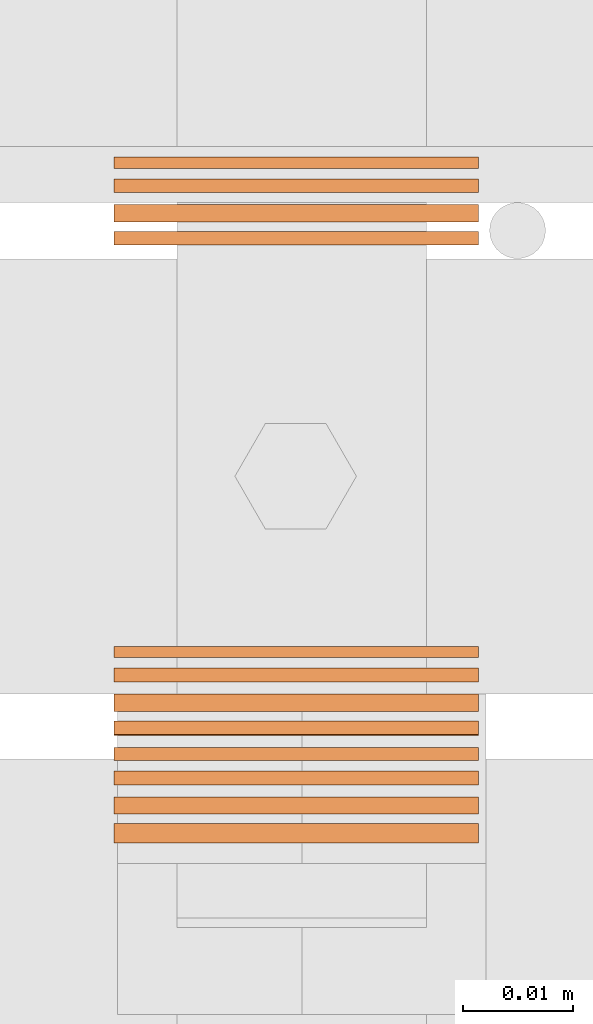
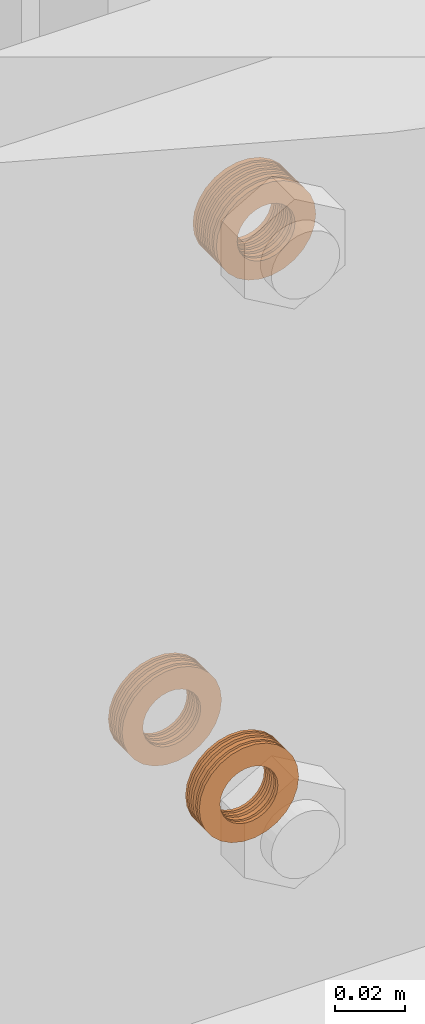
# One storey, part 34 of 44: 5 proxies.
"""IFC4 building model written with IfcOpenShell, lengths in feet."""

from ifc_helpers import new_model, entity, si_unit, converted_unit, derived_unit, direction, frame, frame_2d, origin, origin_2d_with_axis, place, context, subcontext, project, spatial, circle_curve, parameter, trimmed, segment, composite_curve, outline, extrude, source, transform, mapped, material, type_object, type_shapes, element, save


model = new_model("IFC4")

# Units and contexts
model_context = context("Model", 3, precision=0.0001, world=origin(), true_north=direction((6.12303176911189e-17, 1.0)))
body_context = subcontext(model_context, "Body", "Model", "MODEL_VIEW")
ifc_project = project(units=[converted_unit("LENGTHUNIT", "FOOT", entity("IfcRatioMeasure", 0.3048), si_unit("LENGTHUNIT", "METRE"), dimensions=[1, 0, 0, 0, 0, 0, 0]), converted_unit("AREAUNIT", "SQUARE FOOT", entity("IfcRatioMeasure", 0.09290304), si_unit("AREAUNIT", "SQUARE_METRE"), dimensions=[2, 0, 0, 0, 0, 0, 0]), converted_unit("VOLUMEUNIT", "CUBIC FOOT", entity("IfcRatioMeasure", 0.028316846592), si_unit("VOLUMEUNIT", "CUBIC_METRE"), dimensions=[3, 0, 0, 0, 0, 0, 0]), converted_unit("PLANEANGLEUNIT", "DEGREE", entity("IfcRatioMeasure", 0.0174532925199433), si_unit("PLANEANGLEUNIT", "RADIAN"), dimensions=[0, 0, 0, 0, 0, 0, 0]), si_unit("MASSUNIT", "GRAM", prefix="KILO"), derived_unit("MASSDENSITYUNIT", [(si_unit("MASSUNIT", "GRAM", prefix="KILO"), 1), (si_unit("LENGTHUNIT", "METRE"), -3)]), derived_unit("MOMENTOFINERTIAUNIT", [(si_unit("LENGTHUNIT", "METRE"), 4)]), si_unit("TIMEUNIT", "SECOND"), si_unit("FREQUENCYUNIT", "HERTZ"), si_unit("THERMODYNAMICTEMPERATUREUNIT", "DEGREE_CELSIUS"), derived_unit("THERMALTRANSMITTANCEUNIT", [(si_unit("MASSUNIT", "GRAM", prefix="KILO"), 1), (si_unit("THERMODYNAMICTEMPERATUREUNIT", "KELVIN"), -1), (si_unit("TIMEUNIT", "SECOND"), -3)]), derived_unit("VOLUMETRICFLOWRATEUNIT", [(si_unit("LENGTHUNIT", "METRE"), 3), (si_unit("TIMEUNIT", "SECOND"), -1)]), si_unit("ELECTRICCURRENTUNIT", "AMPERE"), si_unit("ELECTRICVOLTAGEUNIT", "VOLT"), si_unit("POWERUNIT", "WATT"), si_unit("FORCEUNIT", "NEWTON"), si_unit("ILLUMINANCEUNIT", "LUX"), si_unit("LUMINOUSFLUXUNIT", "LUMEN"), si_unit("LUMINOUSINTENSITYUNIT", "CANDELA"), derived_unit("USERDEFINED", [(si_unit("MASSUNIT", "GRAM", prefix="KILO"), -1), (si_unit("LENGTHUNIT", "METRE"), -2), (si_unit("TIMEUNIT", "SECOND"), 3), (si_unit("LUMINOUSFLUXUNIT", "LUMEN"), 1)]), derived_unit("LINEARVELOCITYUNIT", [(si_unit("LENGTHUNIT", "METRE"), 1), (si_unit("TIMEUNIT", "SECOND"), -1)]), si_unit("PRESSUREUNIT", "PASCAL"), derived_unit("USERDEFINED", [(si_unit("LENGTHUNIT", "METRE"), -2), (si_unit("MASSUNIT", "GRAM", prefix="KILO"), 1), (si_unit("TIMEUNIT", "SECOND"), -2)]), derived_unit("LINEARFORCEUNIT", [(si_unit("MASSUNIT", "GRAM", prefix="KILO"), 1), (si_unit("LENGTHUNIT", "METRE"), 1), (si_unit("TIMEUNIT", "SECOND"), -2), (si_unit("LENGTHUNIT", "METRE"), -1)]), derived_unit("PLANARFORCEUNIT", [(si_unit("MASSUNIT", "GRAM", prefix="KILO"), 1), (si_unit("LENGTHUNIT", "METRE"), 1), (si_unit("TIMEUNIT", "SECOND"), -2), (si_unit("LENGTHUNIT", "METRE"), -2)])], contexts=[model_context])

# Site, building, storey
site_placement = place(None, origin())
site = spatial("IfcSite", under=ifc_project, at=site_placement, CompositionType="ELEMENT")
building_placement = place(site_placement, origin())
building = spatial("IfcBuilding", under=site, at=building_placement, CompositionType="ELEMENT")
storey_placement = place(building_placement, origin())
storey = spatial("IfcBuildingStorey", under=building, at=storey_placement, CompositionType="ELEMENT", Elevation=0.0)

# Proxies
ifc_material = material(Name="(2) GALV. (FOR DRAINAGE)", Category="Materials")
building_element_proxy_type_1 = type_object("IfcBuildingElementProxyType", Name="WASHER240:WASHER", PredefinedType="NOTDEFINED", material=ifc_material)
shared_shape_1 = source(origin(), body_context, "Body", "SweptSolid", [
    extrude(outline(composite_curve([segment(trimmed(circle_curve(origin_2d_with_axis(), 0.054126587736544), [parameter(360.0)], [parameter(180.0)], True, "PARAMETER"), True, "CONTINUOUS"), segment(trimmed(circle_curve(origin_2d_with_axis(), 0.054126587736544), [parameter(180.0)], [parameter(360.0)], True, "PARAMETER"), True, "CONTINUOUS")], self_intersect=False), holes=[composite_curve([segment(trimmed(circle_curve(frame_2d((0.0, 0.00204962727015712), x_axis=(1.0, 0.0)), 0.031438579453031), [parameter(180.0)], [parameter(360.0)], True, "PARAMETER"), False, "CONTINUOUS"), segment(trimmed(circle_curve(frame_2d((0.0, 0.00204962727015712), x_axis=(1.0, 0.0)), 0.031438579453031), [parameter(360.0)], [parameter(180.0)], True, "PARAMETER"), False, "CONTINUOUS")], self_intersect=False)]), frame((0.0, 0.0593604205315437, 0.0593604205315437), z_axis=(1.0, 0.0, 0.0), x_axis=(0.0, -1.0, 0.0)), (0.0, 0.0, 1.0), 0.00519959634584666),
    extrude(outline(composite_curve([segment(trimmed(circle_curve(origin_2d_with_axis(), 0.054126587736544), [parameter(180.0)], [parameter(360.0)], True, "PARAMETER"), True, "CONTINUOUS"), segment(trimmed(circle_curve(origin_2d_with_axis(), 0.054126587736544), [parameter(360.0)], [parameter(180.0)], True, "PARAMETER"), True, "CONTINUOUS")], self_intersect=False), holes=[composite_curve([segment(trimmed(circle_curve(frame_2d((0.0, 0.00204962727015712), x_axis=(1.0, 0.0)), 0.031438579453031), [parameter(360.0)], [parameter(180.0)], True, "PARAMETER"), False, "CONTINUOUS"), segment(trimmed(circle_curve(frame_2d((0.0, 0.00204962727015712), x_axis=(1.0, 0.0)), 0.031438579453031), [parameter(180.0)], [parameter(360.0)], True, "PARAMETER"), False, "CONTINUOUS")], self_intersect=False)]), frame((0.0385633439132107, 0.0593604205315437, 0.0593604205315437), z_axis=(1.0, 0.0, 0.0), x_axis=(0.0, -1.0, 0.0)), (0.0, 0.0, 1.0), 0.00570828538684509),
    extrude(outline(composite_curve([segment(trimmed(circle_curve(origin_2d_with_axis(), 0.054126587736544), [parameter(180.0)], [parameter(360.0)], True, "PARAMETER"), True, "CONTINUOUS"), segment(trimmed(circle_curve(origin_2d_with_axis(), 0.054126587736544), [parameter(360.0)], [parameter(180.0)], True, "PARAMETER"), True, "CONTINUOUS")], self_intersect=False), holes=[composite_curve([segment(trimmed(circle_curve(frame_2d((0.0, 0.00204962727015712), x_axis=(1.0, 0.0)), 0.031438579453031), [parameter(360.0)], [parameter(180.0)], True, "PARAMETER"), False, "CONTINUOUS"), segment(trimmed(circle_curve(frame_2d((0.0, 0.00204962727015712), x_axis=(1.0, 0.0)), 0.031438579453031), [parameter(180.0)], [parameter(360.0)], True, "PARAMETER"), False, "CONTINUOUS")], self_intersect=False)]), frame((0.0306092216351317, 0.0593604205315437, 0.0593604205315437), z_axis=(1.0, 0.0, 0.0), x_axis=(0.0, -1.0, 0.0)), (0.0, 0.0, 1.0), 0.0051228935196832),
    extrude(outline(composite_curve([segment(trimmed(circle_curve(origin_2d_with_axis(), 0.054126587736544), [parameter(180.0)], [parameter(360.0)], True, "PARAMETER"), True, "CONTINUOUS"), segment(trimmed(circle_curve(origin_2d_with_axis(), 0.054126587736544), [parameter(360.0)], [parameter(180.0)], True, "PARAMETER"), True, "CONTINUOUS")], self_intersect=False), holes=[composite_curve([segment(trimmed(circle_curve(frame_2d((0.0, 0.00204962727015712), x_axis=(1.0, 0.0)), 0.031438579453031), [parameter(360.0)], [parameter(180.0)], True, "PARAMETER"), False, "CONTINUOUS"), segment(trimmed(circle_curve(frame_2d((0.0, 0.00204962727015712), x_axis=(1.0, 0.0)), 0.031438579453031), [parameter(180.0)], [parameter(360.0)], True, "PARAMETER"), False, "CONTINUOUS")], self_intersect=False)]), frame((0.0159873593368047, 0.0593604205315437, 0.0593604205315437), z_axis=(1.0, 0.0, 0.0), x_axis=(0.0, -1.0, 0.0)), (0.0, 0.0, 1.0), 0.00383409930736889),
    extrude(outline(composite_curve([segment(trimmed(circle_curve(origin_2d_with_axis(), 0.054126587736544), [parameter(180.0)], [parameter(360.0)], True, "PARAMETER"), True, "CONTINUOUS"), segment(trimmed(circle_curve(origin_2d_with_axis(), 0.054126587736544), [parameter(360.0)], [parameter(180.0)], True, "PARAMETER"), True, "CONTINUOUS")], self_intersect=False), holes=[composite_curve([segment(trimmed(circle_curve(frame_2d((0.0, 0.00204962727015712), x_axis=(1.0, 0.0)), 0.031438579453031), [parameter(360.0)], [parameter(180.0)], True, "PARAMETER"), False, "CONTINUOUS"), segment(trimmed(circle_curve(frame_2d((0.0, 0.00204962727015712), x_axis=(1.0, 0.0)), 0.031438579453031), [parameter(180.0)], [parameter(360.0)], True, "PARAMETER"), False, "CONTINUOUS")], self_intersect=False)]), frame((0.0229205971854753, 0.0593604205315437, 0.0593604205315437), z_axis=(1.0, 0.0, 0.0), x_axis=(0.0, -1.0, 0.0)), (0.0, 0.0, 1.0), 0.00412198282083409),
    extrude(outline(composite_curve([segment(trimmed(circle_curve(origin_2d_with_axis(), 0.054126587736544), [parameter(180.0)], [parameter(360.0)], True, "PARAMETER"), True, "CONTINUOUS"), segment(trimmed(circle_curve(origin_2d_with_axis(), 0.054126587736544), [parameter(360.0)], [parameter(180.0)], True, "PARAMETER"), True, "CONTINUOUS")], self_intersect=False), holes=[composite_curve([segment(trimmed(circle_curve(frame_2d((0.0, 0.00204962727015712), x_axis=(1.0, 0.0)), 0.031438579453031), [parameter(360.0)], [parameter(180.0)], True, "PARAMETER"), False, "CONTINUOUS"), segment(trimmed(circle_curve(frame_2d((0.0, 0.00204962727015712), x_axis=(1.0, 0.0)), 0.031438579453031), [parameter(180.0)], [parameter(360.0)], True, "PARAMETER"), False, "CONTINUOUS")], self_intersect=False)]), frame((0.00829873488714838, 0.0593604205315437, 0.0593604205315437), z_axis=(1.0, 0.0, 0.0), x_axis=(0.0, -1.0, 0.0)), (0.0, 0.0, 1.0), 0.00412198282083409),
])
type_shapes(building_element_proxy_type_1, [shared_shape_1])
proxy_1_placement = place(storey_placement, frame((1492.59585645703, 4.75787225520091, 9.57411707518539), z_axis=(0.0, 0.0, 1.0), x_axis=(0.0, -1.0, 0.0)))
element("IfcBuildingElementProxy", 1, at=proxy_1_placement, inside=storey, type_object=building_element_proxy_type_1, material=ifc_material, Name="WASHER240:WASHER", ObjectType="WASHER240:WASHER", PredefinedType="NOTDEFINED", context=body_context, shape_type="MappedRepresentation", body=[
    mapped(shared_shape_1, transform((0.0, 0.0, 0.0), scale=1.0)),
])
building_element_proxy_type_2 = type_object("IfcBuildingElementProxyType", Name="WASHER241:WASHER", PredefinedType="NOTDEFINED", material=ifc_material)
shared_shape_2 = source(origin(), body_context, "Body", "SweptSolid", [
    extrude(outline(composite_curve([segment(trimmed(circle_curve(origin_2d_with_axis(), 0.054126587736544), [parameter(360.0)], [parameter(180.0)], True, "PARAMETER"), True, "CONTINUOUS"), segment(trimmed(circle_curve(origin_2d_with_axis(), 0.054126587736544), [parameter(180.0)], [parameter(360.0)], True, "PARAMETER"), True, "CONTINUOUS")], self_intersect=False), holes=[composite_curve([segment(trimmed(circle_curve(frame_2d((0.0, 0.00204962727015712), x_axis=(1.0, 0.0)), 0.031438579453031), [parameter(180.0)], [parameter(360.0)], True, "PARAMETER"), False, "CONTINUOUS"), segment(trimmed(circle_curve(frame_2d((0.0, 0.00204962727015712), x_axis=(1.0, 0.0)), 0.031438579453031), [parameter(360.0)], [parameter(180.0)], True, "PARAMETER"), False, "CONTINUOUS")], self_intersect=False)]), frame((0.0, 0.0593604205315437, 0.0593604205315437), z_axis=(1.0, 0.0, 0.0), x_axis=(0.0, -1.0, 0.0)), (0.0, 0.0, 1.0), 0.00332179672204802),
    extrude(outline(composite_curve([segment(trimmed(circle_curve(origin_2d_with_axis(), 0.054126587736544), [parameter(180.0)], [parameter(360.0)], True, "PARAMETER"), True, "CONTINUOUS"), segment(trimmed(circle_curve(origin_2d_with_axis(), 0.054126587736544), [parameter(360.0)], [parameter(180.0)], True, "PARAMETER"), True, "CONTINUOUS")], self_intersect=False), holes=[composite_curve([segment(trimmed(circle_curve(frame_2d((0.0, 0.00204962727015712), x_axis=(1.0, 0.0)), 0.031438579453031), [parameter(360.0)], [parameter(180.0)], True, "PARAMETER"), False, "CONTINUOUS"), segment(trimmed(circle_curve(frame_2d((0.0, 0.00204962727015712), x_axis=(1.0, 0.0)), 0.031438579453031), [parameter(180.0)], [parameter(360.0)], True, "PARAMETER"), False, "CONTINUOUS")], self_intersect=False)]), frame((0.0220636819910851, 0.0593604205315437, 0.0593604205315437), z_axis=(1.0, 0.0, 0.0), x_axis=(0.0, -1.0, 0.0)), (0.0, 0.0, 1.0), 0.00404999031002262),
    extrude(outline(composite_curve([segment(trimmed(circle_curve(origin_2d_with_axis(), 0.054126587736544), [parameter(180.0)], [parameter(360.0)], True, "PARAMETER"), True, "CONTINUOUS"), segment(trimmed(circle_curve(origin_2d_with_axis(), 0.054126587736544), [parameter(360.0)], [parameter(180.0)], True, "PARAMETER"), True, "CONTINUOUS")], self_intersect=False), holes=[composite_curve([segment(trimmed(circle_curve(frame_2d((0.0, 0.00204962727015712), x_axis=(1.0, 0.0)), 0.031438579453031), [parameter(360.0)], [parameter(180.0)], True, "PARAMETER"), False, "CONTINUOUS"), segment(trimmed(circle_curve(frame_2d((0.0, 0.00204962727015712), x_axis=(1.0, 0.0)), 0.031438579453031), [parameter(180.0)], [parameter(360.0)], True, "PARAMETER"), False, "CONTINUOUS")], self_intersect=False)]), frame((0.00642093526334975, 0.0593604205315437, 0.0593604205315437), z_axis=(1.0, 0.0, 0.0), x_axis=(0.0, -1.0, 0.0)), (0.0, 0.0, 1.0), 0.00412198282083409),
    extrude(outline(composite_curve([segment(trimmed(circle_curve(origin_2d_with_axis(), 0.054126587736544), [parameter(180.0)], [parameter(360.0)], True, "PARAMETER"), True, "CONTINUOUS"), segment(trimmed(circle_curve(origin_2d_with_axis(), 0.054126587736544), [parameter(360.0)], [parameter(180.0)], True, "PARAMETER"), True, "CONTINUOUS")], self_intersect=False), holes=[composite_curve([segment(trimmed(circle_curve(frame_2d((0.0, 0.00204962727015712), x_axis=(1.0, 0.0)), 0.031438579453031), [parameter(360.0)], [parameter(180.0)], True, "PARAMETER"), False, "CONTINUOUS"), segment(trimmed(circle_curve(frame_2d((0.0, 0.00204962727015712), x_axis=(1.0, 0.0)), 0.031438579453031), [parameter(180.0)], [parameter(360.0)], True, "PARAMETER"), False, "CONTINUOUS")], self_intersect=False)]), frame((0.0141095597130061, 0.0593604205315437, 0.0593604205315437), z_axis=(1.0, 0.0, 0.0), x_axis=(0.0, -1.0, 0.0)), (0.0, 0.0, 1.0), 0.0051228935196832),
])
type_shapes(building_element_proxy_type_2, [shared_shape_2])
proxy_2_placement = place(storey_placement, frame((1492.59585645703, 4.9172173612744, 8.90822083537735), z_axis=(0.0, 0.0, 1.0), x_axis=(0.0, -1.0, 0.0)))
element("IfcBuildingElementProxy", 2, at=proxy_2_placement, inside=storey, type_object=building_element_proxy_type_2, material=ifc_material, Name="WASHER241:WASHER", ObjectType="WASHER241:WASHER", PredefinedType="NOTDEFINED", context=body_context, shape_type="MappedRepresentation", body=[
    mapped(shared_shape_2, transform((0.0, 0.0, 0.0), scale=1.0)),
])
building_element_proxy_type_3 = type_object("IfcBuildingElementProxyType", Name="WASHER242:WASHER", PredefinedType="NOTDEFINED", material=ifc_material)
shared_shape_3 = source(origin(), body_context, "Body", "SweptSolid", [
    extrude(outline(composite_curve([segment(trimmed(circle_curve(origin_2d_with_axis(), 0.054126587736544), [parameter(360.0)], [parameter(180.0)], True, "PARAMETER"), True, "CONTINUOUS"), segment(trimmed(circle_curve(origin_2d_with_axis(), 0.054126587736544), [parameter(180.0)], [parameter(360.0)], True, "PARAMETER"), True, "CONTINUOUS")], self_intersect=False), holes=[composite_curve([segment(trimmed(circle_curve(frame_2d((0.0, 0.00204962727015712), x_axis=(1.0, 0.0)), 0.031438579453031), [parameter(180.0)], [parameter(360.0)], True, "PARAMETER"), False, "CONTINUOUS"), segment(trimmed(circle_curve(frame_2d((0.0, 0.00204962727015712), x_axis=(1.0, 0.0)), 0.031438579453031), [parameter(360.0)], [parameter(180.0)], True, "PARAMETER"), False, "CONTINUOUS")], self_intersect=False)]), frame((0.0, 0.0593604205315437, 0.0593604205315437), z_axis=(1.0, 0.0, 0.0), x_axis=(0.0, -1.0, 0.0)), (0.0, 0.0, 1.0), 0.00332179672204802),
    extrude(outline(composite_curve([segment(trimmed(circle_curve(origin_2d_with_axis(), 0.054126587736544), [parameter(180.0)], [parameter(360.0)], True, "PARAMETER"), True, "CONTINUOUS"), segment(trimmed(circle_curve(origin_2d_with_axis(), 0.054126587736544), [parameter(360.0)], [parameter(180.0)], True, "PARAMETER"), True, "CONTINUOUS")], self_intersect=False), holes=[composite_curve([segment(trimmed(circle_curve(frame_2d((0.0, 0.00204962727015712), x_axis=(1.0, 0.0)), 0.031438579453031), [parameter(360.0)], [parameter(180.0)], True, "PARAMETER"), False, "CONTINUOUS"), segment(trimmed(circle_curve(frame_2d((0.0, 0.00204962727015712), x_axis=(1.0, 0.0)), 0.031438579453031), [parameter(180.0)], [parameter(360.0)], True, "PARAMETER"), False, "CONTINUOUS")], self_intersect=False)]), frame((0.0220636819910851, 0.0593604205315437, 0.0593604205315437), z_axis=(1.0, 0.0, 0.0), x_axis=(0.0, -1.0, 0.0)), (0.0, 0.0, 1.0), 0.00404999031002262),
    extrude(outline(composite_curve([segment(trimmed(circle_curve(origin_2d_with_axis(), 0.054126587736544), [parameter(180.0)], [parameter(360.0)], True, "PARAMETER"), True, "CONTINUOUS"), segment(trimmed(circle_curve(origin_2d_with_axis(), 0.054126587736544), [parameter(360.0)], [parameter(180.0)], True, "PARAMETER"), True, "CONTINUOUS")], self_intersect=False), holes=[composite_curve([segment(trimmed(circle_curve(frame_2d((0.0, 0.00204962727015712), x_axis=(1.0, 0.0)), 0.031438579453031), [parameter(360.0)], [parameter(180.0)], True, "PARAMETER"), False, "CONTINUOUS"), segment(trimmed(circle_curve(frame_2d((0.0, 0.00204962727015712), x_axis=(1.0, 0.0)), 0.031438579453031), [parameter(180.0)], [parameter(360.0)], True, "PARAMETER"), False, "CONTINUOUS")], self_intersect=False)]), frame((0.00642093526334975, 0.0593604205315437, 0.0593604205315437), z_axis=(1.0, 0.0, 0.0), x_axis=(0.0, -1.0, 0.0)), (0.0, 0.0, 1.0), 0.00412198282083409),
    extrude(outline(composite_curve([segment(trimmed(circle_curve(origin_2d_with_axis(), 0.054126587736544), [parameter(180.0)], [parameter(360.0)], True, "PARAMETER"), True, "CONTINUOUS"), segment(trimmed(circle_curve(origin_2d_with_axis(), 0.054126587736544), [parameter(360.0)], [parameter(180.0)], True, "PARAMETER"), True, "CONTINUOUS")], self_intersect=False), holes=[composite_curve([segment(trimmed(circle_curve(frame_2d((0.0, 0.00204962727015712), x_axis=(1.0, 0.0)), 0.031438579453031), [parameter(360.0)], [parameter(180.0)], True, "PARAMETER"), False, "CONTINUOUS"), segment(trimmed(circle_curve(frame_2d((0.0, 0.00204962727015712), x_axis=(1.0, 0.0)), 0.031438579453031), [parameter(180.0)], [parameter(360.0)], True, "PARAMETER"), False, "CONTINUOUS")], self_intersect=False)]), frame((0.0141095597130061, 0.0593604205315437, 0.0593604205315437), z_axis=(1.0, 0.0, 0.0), x_axis=(0.0, -1.0, 0.0)), (0.0, 0.0, 1.0), 0.0051228935196832),
])
type_shapes(building_element_proxy_type_3, [shared_shape_3])
proxy_3_placement = place(storey_placement, frame((1492.59585645703, 4.77190511208776, 8.90822083537735), z_axis=(0.0, 0.0, 1.0), x_axis=(0.0, -1.0, 0.0)))
element("IfcBuildingElementProxy", 3, at=proxy_3_placement, inside=storey, type_object=building_element_proxy_type_3, material=ifc_material, Name="WASHER242:WASHER", ObjectType="WASHER242:WASHER", PredefinedType="NOTDEFINED", context=body_context, shape_type="MappedRepresentation", body=[
    mapped(shared_shape_3, transform((0.0, 0.0, 0.0), scale=1.0)),
])
building_element_proxy_type_4 = type_object("IfcBuildingElementProxyType", Name="WASHER243:WASHER", PredefinedType="NOTDEFINED", material=ifc_material)
shared_shape_4 = source(origin(), body_context, "Body", "SweptSolid", [
    extrude(outline(composite_curve([segment(trimmed(circle_curve(origin_2d_with_axis(), 0.054126587736544), [parameter(360.0)], [parameter(180.0)], True, "PARAMETER"), True, "CONTINUOUS"), segment(trimmed(circle_curve(origin_2d_with_axis(), 0.054126587736544), [parameter(180.0)], [parameter(360.0)], True, "PARAMETER"), True, "CONTINUOUS")], self_intersect=False), holes=[composite_curve([segment(trimmed(circle_curve(frame_2d((0.0, 0.00204962727015712), x_axis=(1.0, 0.0)), 0.031438579453031), [parameter(180.0)], [parameter(360.0)], True, "PARAMETER"), False, "CONTINUOUS"), segment(trimmed(circle_curve(frame_2d((0.0, 0.00204962727015712), x_axis=(1.0, 0.0)), 0.031438579453031), [parameter(360.0)], [parameter(180.0)], True, "PARAMETER"), False, "CONTINUOUS")], self_intersect=False)]), frame((0.0, 0.0593604205315437, 0.0593604205315437), z_axis=(1.0, 0.0, 0.0), x_axis=(0.0, -1.0, 0.0)), (0.0, 0.0, 1.0), 0.00332179672204802),
    extrude(outline(composite_curve([segment(trimmed(circle_curve(origin_2d_with_axis(), 0.054126587736544), [parameter(180.0)], [parameter(360.0)], True, "PARAMETER"), True, "CONTINUOUS"), segment(trimmed(circle_curve(origin_2d_with_axis(), 0.054126587736544), [parameter(360.0)], [parameter(180.0)], True, "PARAMETER"), True, "CONTINUOUS")], self_intersect=False), holes=[composite_curve([segment(trimmed(circle_curve(frame_2d((0.0, 0.00204962727015712), x_axis=(1.0, 0.0)), 0.031438579453031), [parameter(360.0)], [parameter(180.0)], True, "PARAMETER"), False, "CONTINUOUS"), segment(trimmed(circle_curve(frame_2d((0.0, 0.00204962727015712), x_axis=(1.0, 0.0)), 0.031438579453031), [parameter(180.0)], [parameter(360.0)], True, "PARAMETER"), False, "CONTINUOUS")], self_intersect=False)]), frame((0.0220636819910851, 0.0593604205315437, 0.0593604205315437), z_axis=(1.0, 0.0, 0.0), x_axis=(0.0, -1.0, 0.0)), (0.0, 0.0, 1.0), 0.00404999031002262),
    extrude(outline(composite_curve([segment(trimmed(circle_curve(origin_2d_with_axis(), 0.054126587736544), [parameter(180.0)], [parameter(360.0)], True, "PARAMETER"), True, "CONTINUOUS"), segment(trimmed(circle_curve(origin_2d_with_axis(), 0.054126587736544), [parameter(360.0)], [parameter(180.0)], True, "PARAMETER"), True, "CONTINUOUS")], self_intersect=False), holes=[composite_curve([segment(trimmed(circle_curve(frame_2d((0.0, 0.00204962727015712), x_axis=(1.0, 0.0)), 0.031438579453031), [parameter(360.0)], [parameter(180.0)], True, "PARAMETER"), False, "CONTINUOUS"), segment(trimmed(circle_curve(frame_2d((0.0, 0.00204962727015712), x_axis=(1.0, 0.0)), 0.031438579453031), [parameter(180.0)], [parameter(360.0)], True, "PARAMETER"), False, "CONTINUOUS")], self_intersect=False)]), frame((0.00642093526334975, 0.0593604205315437, 0.0593604205315437), z_axis=(1.0, 0.0, 0.0), x_axis=(0.0, -1.0, 0.0)), (0.0, 0.0, 1.0), 0.00412198282083409),
    extrude(outline(composite_curve([segment(trimmed(circle_curve(origin_2d_with_axis(), 0.054126587736544), [parameter(180.0)], [parameter(360.0)], True, "PARAMETER"), True, "CONTINUOUS"), segment(trimmed(circle_curve(origin_2d_with_axis(), 0.054126587736544), [parameter(360.0)], [parameter(180.0)], True, "PARAMETER"), True, "CONTINUOUS")], self_intersect=False), holes=[composite_curve([segment(trimmed(circle_curve(frame_2d((0.0, 0.00204962727015712), x_axis=(1.0, 0.0)), 0.031438579453031), [parameter(360.0)], [parameter(180.0)], True, "PARAMETER"), False, "CONTINUOUS"), segment(trimmed(circle_curve(frame_2d((0.0, 0.00204962727015712), x_axis=(1.0, 0.0)), 0.031438579453031), [parameter(180.0)], [parameter(360.0)], True, "PARAMETER"), False, "CONTINUOUS")], self_intersect=False)]), frame((0.0141095597130061, 0.0593604205315437, 0.0593604205315437), z_axis=(1.0, 0.0, 0.0), x_axis=(0.0, -1.0, 0.0)), (0.0, 0.0, 1.0), 0.0051228935196832),
])
type_shapes(building_element_proxy_type_4, [shared_shape_4])
proxy_4_placement = place(storey_placement, frame((1492.59585645703, 4.77190511208776, 8.90822083537735), z_axis=(0.0, 0.0, 1.0), x_axis=(0.0, -1.0, 0.0)))
element("IfcBuildingElementProxy", 4, at=proxy_4_placement, inside=storey, type_object=building_element_proxy_type_4, material=ifc_material, Name="WASHER243:WASHER", ObjectType="WASHER243:WASHER", PredefinedType="NOTDEFINED", context=body_context, shape_type="MappedRepresentation", body=[
    mapped(shared_shape_4, transform((0.0, 0.0, 0.0), scale=1.0)),
])
building_element_proxy_type_5 = type_object("IfcBuildingElementProxyType", Name="WASHER244:WASHER", PredefinedType="NOTDEFINED", material=ifc_material)
shared_shape_5 = source(origin(), body_context, "Body", "SweptSolid", [
    extrude(outline(composite_curve([segment(trimmed(circle_curve(origin_2d_with_axis(), 0.054126587736544), [parameter(360.0)], [parameter(180.0)], True, "PARAMETER"), True, "CONTINUOUS"), segment(trimmed(circle_curve(origin_2d_with_axis(), 0.054126587736544), [parameter(180.0)], [parameter(360.0)], True, "PARAMETER"), True, "CONTINUOUS")], self_intersect=False), holes=[composite_curve([segment(trimmed(circle_curve(frame_2d((0.0, 0.00204962727015712), x_axis=(1.0, 0.0)), 0.031438579453031), [parameter(180.0)], [parameter(360.0)], True, "PARAMETER"), False, "CONTINUOUS"), segment(trimmed(circle_curve(frame_2d((0.0, 0.00204962727015712), x_axis=(1.0, 0.0)), 0.031438579453031), [parameter(360.0)], [parameter(180.0)], True, "PARAMETER"), False, "CONTINUOUS")], self_intersect=False)]), frame((0.0, 0.0593604205315437, 0.0593604205315437), z_axis=(1.0, 0.0, 0.0), x_axis=(0.0, -1.0, 0.0)), (0.0, 0.0, 1.0), 0.00332179672204802),
    extrude(outline(composite_curve([segment(trimmed(circle_curve(origin_2d_with_axis(), 0.054126587736544), [parameter(180.0)], [parameter(360.0)], True, "PARAMETER"), True, "CONTINUOUS"), segment(trimmed(circle_curve(origin_2d_with_axis(), 0.054126587736544), [parameter(360.0)], [parameter(180.0)], True, "PARAMETER"), True, "CONTINUOUS")], self_intersect=False), holes=[composite_curve([segment(trimmed(circle_curve(frame_2d((0.0, 0.00204962727015712), x_axis=(1.0, 0.0)), 0.031438579453031), [parameter(360.0)], [parameter(180.0)], True, "PARAMETER"), False, "CONTINUOUS"), segment(trimmed(circle_curve(frame_2d((0.0, 0.00204962727015712), x_axis=(1.0, 0.0)), 0.031438579453031), [parameter(180.0)], [parameter(360.0)], True, "PARAMETER"), False, "CONTINUOUS")], self_intersect=False)]), frame((0.0220636819910851, 0.0593604205315437, 0.0593604205315437), z_axis=(1.0, 0.0, 0.0), x_axis=(0.0, -1.0, 0.0)), (0.0, 0.0, 1.0), 0.00404999031002262),
    extrude(outline(composite_curve([segment(trimmed(circle_curve(origin_2d_with_axis(), 0.054126587736544), [parameter(180.0)], [parameter(360.0)], True, "PARAMETER"), True, "CONTINUOUS"), segment(trimmed(circle_curve(origin_2d_with_axis(), 0.054126587736544), [parameter(360.0)], [parameter(180.0)], True, "PARAMETER"), True, "CONTINUOUS")], self_intersect=False), holes=[composite_curve([segment(trimmed(circle_curve(frame_2d((0.0, 0.00204962727015712), x_axis=(1.0, 0.0)), 0.031438579453031), [parameter(360.0)], [parameter(180.0)], True, "PARAMETER"), False, "CONTINUOUS"), segment(trimmed(circle_curve(frame_2d((0.0, 0.00204962727015712), x_axis=(1.0, 0.0)), 0.031438579453031), [parameter(180.0)], [parameter(360.0)], True, "PARAMETER"), False, "CONTINUOUS")], self_intersect=False)]), frame((0.00642093526334975, 0.0593604205315437, 0.0593604205315437), z_axis=(1.0, 0.0, 0.0), x_axis=(0.0, -1.0, 0.0)), (0.0, 0.0, 1.0), 0.00412198282083409),
    extrude(outline(composite_curve([segment(trimmed(circle_curve(origin_2d_with_axis(), 0.054126587736544), [parameter(180.0)], [parameter(360.0)], True, "PARAMETER"), True, "CONTINUOUS"), segment(trimmed(circle_curve(origin_2d_with_axis(), 0.054126587736544), [parameter(360.0)], [parameter(180.0)], True, "PARAMETER"), True, "CONTINUOUS")], self_intersect=False), holes=[composite_curve([segment(trimmed(circle_curve(frame_2d((0.0, 0.00204962727015712), x_axis=(1.0, 0.0)), 0.031438579453031), [parameter(360.0)], [parameter(180.0)], True, "PARAMETER"), False, "CONTINUOUS"), segment(trimmed(circle_curve(frame_2d((0.0, 0.00204962727015712), x_axis=(1.0, 0.0)), 0.031438579453031), [parameter(180.0)], [parameter(360.0)], True, "PARAMETER"), False, "CONTINUOUS")], self_intersect=False)]), frame((0.0141095597130061, 0.0593604205315437, 0.0593604205315437), z_axis=(1.0, 0.0, 0.0), x_axis=(0.0, -1.0, 0.0)), (0.0, 0.0, 1.0), 0.0051228935196832),
])
type_shapes(building_element_proxy_type_5, [shared_shape_5])
proxy_5_placement = place(storey_placement, frame((1492.59585645703, 4.77190511208776, 8.90822083537735), z_axis=(0.0, 0.0, 1.0), x_axis=(0.0, -1.0, 0.0)))
element("IfcBuildingElementProxy", 5, at=proxy_5_placement, inside=storey, type_object=building_element_proxy_type_5, material=ifc_material, Name="WASHER244:WASHER", ObjectType="WASHER244:WASHER", PredefinedType="NOTDEFINED", context=body_context, shape_type="MappedRepresentation", body=[
    mapped(shared_shape_5, transform((0.0, 0.0, 0.0), scale=1.0)),
])

save(model, "model.ifc")
